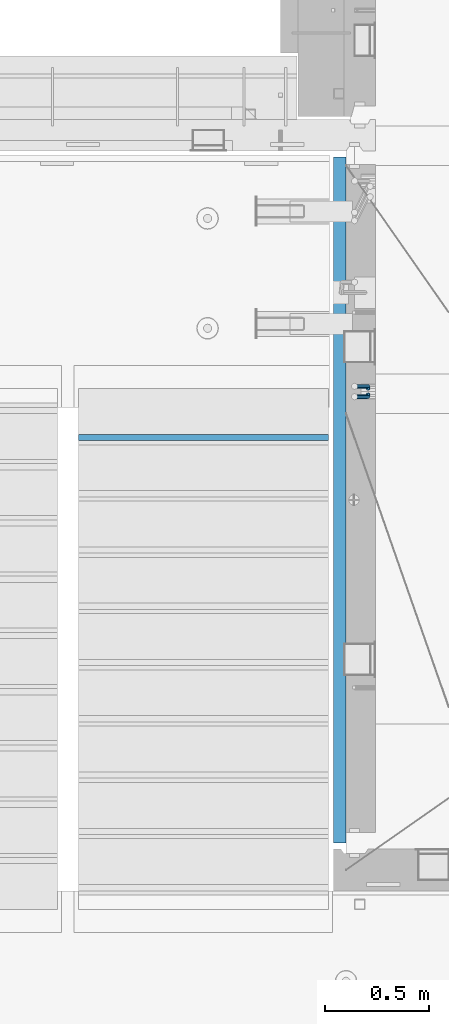
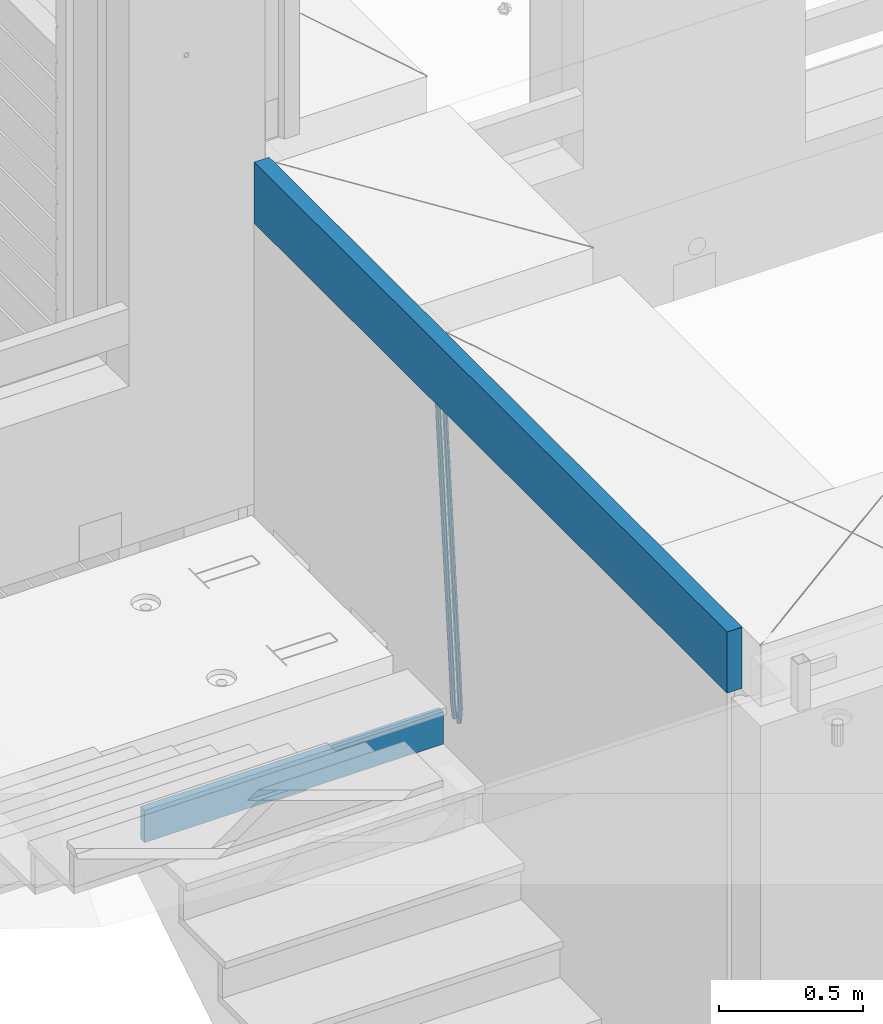
# One storey, part 120 of 349: 4 beams, 2 elements without a shape of their own.
"""IFC2X3 building model written with IfcOpenShell, lengths in millimetres."""

from ifc_helpers import new_model, si_unit, frame, origin_with_axes, place, context, subcontext, project, spatial, faceted_brep, material, type_object, element, aggregate, save


model = new_model("IFC2X3")

# Units and contexts
model_context = context("Model", 3, precision=1e-05, world=origin_with_axes())
body_context = subcontext(model_context, "Body", "Model", "MODEL_VIEW")
ifc_project = project(units=[si_unit("LENGTHUNIT", "METRE", prefix="MILLI"), si_unit("AREAUNIT", "SQUARE_METRE"), si_unit("VOLUMEUNIT", "CUBIC_METRE"), si_unit("MASSUNIT", "GRAM", prefix="KILO"), si_unit("TIMEUNIT", "SECOND"), si_unit("PLANEANGLEUNIT", "RADIAN"), si_unit("SOLIDANGLEUNIT", "STERADIAN"), si_unit("THERMODYNAMICTEMPERATUREUNIT", "DEGREE_CELSIUS"), si_unit("LUMINOUSINTENSITYUNIT", "LUMEN")], contexts=[model_context])

# Site, building, storey
site_placement = place(None, origin_with_axes())
site = spatial("IfcSite", under=ifc_project, at=site_placement, CompositionType="ELEMENT")
building_placement = place(site_placement, origin_with_axes())
building = spatial("IfcBuilding", under=site, at=building_placement, CompositionType="ELEMENT")
storey_placement = place(building_placement, origin_with_axes())
storey = spatial("IfcBuildingStorey", under=building, at=storey_placement, Name="4", CompositionType="ELEMENT", Elevation=0.0)

# Assembly, beams
assembly_1_placement = place(storey_placement, origin_with_axes())
assembly_1 = element("IfcElementAssembly", 1, at=assembly_1_placement, inside=storey, AssemblyPlace="NOTDEFINED", PredefinedType="REINFORCEMENT_UNIT")
ifc_material_1 = material()
beam_type_1 = type_object("IfcBeamType", Name="D20", PredefinedType="NOTDEFINED")
beam_1_placement = place(assembly_1_placement, frame((22375.0000022791, 19290.4700000039, 91985.0), z_axis=(-0.15890508605452, 0.973589036334047, -0.163931577056242), x_axis=(-0.0263727870048703, 0.161796289029781, 0.986471711181718)))
beam_1 = element("IfcBeam", 2, at=beam_1_placement, type_object=beam_type_1, material=ifc_material_1, Name="JM20", ObjectType="D20", context=body_context, shape_type="Brep", body=[
    faceted_brep([(0.0, -10.0, 0.0), (-4.19531716033816e-08, -7.07106781186667, -7.07106781187031), (60.5120847452927, -7.07106784077769, -7.0710678127632), (60.5120847456128, -10.000000028911, -8.96534402272664e-10), (0.0, 0.0, -10.0), (60.5120847479557, -2.89146555587649e-08, -10.0000000008984), (4.196772351861e-08, 7.07106781186303, -7.07106781186667), (60.5120847520593, 7.07106778294838, -7.0710678127632), (0.0, 10.0, 0.0), (60.5120847551734, 9.99999997108898, -8.94715412869118e-10), (4.196772351861e-08, 7.07106781185939, 7.07106781185939), (60.512084755479, 7.07106778295201, 7.07106781097195), (0.0, 0.0, 10.0), (60.512084752816, -2.89110175799578e-08, 9.9999999991071), (-4.19531716033816e-08, -7.07106781187031, 7.07106781185939), (60.5120847487415, -7.07106784077769, 7.07106781096832), (61.1107048256381, -7.07106784106145, -7.07106781277048), (61.616696962592, -10.0000000294385, -9.12905306904577e-10), (61.0120847479702, -2.91511241812259e-08, -10.0000000009038), (61.3786070335627, 7.07106778254092, -7.0710678127723), (61.9955678984406, 9.99999997037958, -9.2018126451876e-10), (62.5015600354091, 7.07106778200614, 7.07106781093921), (62.6001801130624, -2.9907823773101e-08, 9.99999999907436), (62.2336578274699, -7.07106784159623, 7.07106781094103), (61.7013993430301, -7.09359767751084, -7.16550506250837), (62.7066844218498, -10.0415735305724, -0.174261679103211), (61.505464887392, -0.0188181720659486, -10.0788791204338), (62.2336568017054, 7.03845510227256, -7.207768842012), (63.4594101385883, 9.94416717476997, -0.234031689273024), (64.464695217408, 6.99619132171574, 6.75721169413032), (64.6606296730461, -0.0785881837327906, 9.67058575205397), (63.9324377587182, -7.1358614580713, 6.79947547363395), (179.287252569251, -11.5784709304826, -25.9645361348155), (180.292537648071, -14.5264467835441, -18.973292751414), (179.091318113613, -4.50369142503769, -28.877910192741), (179.819510027926, 2.55358184929719, -26.0067999143191), (181.045263364809, 5.45929392180187, -19.033062761582), (182.050548443614, 2.511318068744, -12.0418193781786), (182.246482899252, -4.56346143670453, -9.12844532025679), (181.518290984939, -11.6207347110394, -11.9995555986786), (179.796944029818, -11.5979112078276, -26.0460230258138), (180.785917787493, -14.5452649264626, -19.0521718709458), (179.631039013402, -4.52427706319941, -28.9641980384947), (180.385387646791, 2.53199856077117, -26.0972695639282), (181.618102731314, 5.43744510340548, -19.1246454201662), (182.607076488988, 2.49009138477413, -12.1307942652963), (182.772981505375, -4.58354275985403, -9.21261925261729), (182.018632872001, -11.6398183838246, -12.0795477271802), (180.306575384253, -11.6215474691344, -26.1267734773298), (181.279244090445, -14.5681079330752, -19.1303214631914), (180.170689328603, -4.54931932109321, -29.0497458967745), (180.951186131948, 2.5057611781267, -26.1870011206463), (182.190861352254, 5.41092355571527, -19.2154962132006), (183.16353005846, 2.46436309177807, -12.2190441990567), (183.299416114096, -4.60786505625947, -9.29607177961748), (182.518919310765, -11.662945555483, -12.1588165557403), (300.637581828458, -17.193417372393, -45.2021641841727), (301.610250534635, -20.1399778363302, -38.2057121700307), (300.501695772793, -10.1211892243555, -48.125136603612), (301.282192576138, -3.06610872513556, -45.2623918274874), (302.521867796473, -0.160946347543359, -38.2908869200398), (303.494536502651, -3.10750681148056, -31.2944349058978), (303.630422558286, -10.1797349595217, -28.3714624864531), (302.849925754956, -17.2348154587417, -31.2342072625831), (301.135146648914, -17.2164568742628, -45.2810403078945), (302.103568397841, -20.1628206848691, -38.2839150477537), (301.007079483054, -10.1445907761881, -48.2052522115043), (301.794386909154, -3.08982563961035, -45.3435870847131), (303.035874914756, -0.184747202180006, -38.3723695478091), (304.004296663683, -3.13111101278264, -31.3752442876664), (304.132363829543, -10.2029771108573, -28.4510323840584), (303.345056403443, -17.2577422474315, -31.3126975108532), (301.632689949649, -17.2405558216851, -45.3597353949606), (302.596865217929, -20.1867113775443, -38.3619373656909), (301.512440876206, -10.1690694440185, -48.2851865283189), (302.306558273951, -3.11463305844518, -45.424601167904), (303.549858941391, -0.209639824737678, -38.4536714215171), (304.514034209686, -3.15579538060047, -31.4558733922438), (304.634283283129, -10.2272817582634, -28.5304222588836), (303.840165885384, -17.2817181438368, -31.3910076193022), (1282.62444446853, -64.7506719518351, -200.525713980774), (1283.58861973681, -67.6968275076943, -193.527915951503), (1282.50419539507, -57.6791855741649, -203.451165114133), (1283.29831279283, -50.6247491885915, -200.590579753716), (1284.54161346027, -47.7197559548877, -193.619650007329), (1285.50578872855, -50.6659115107432, -186.621851978058), (1285.62603780199, -57.7373978884098, -183.696400844703), (1284.83192040426, -64.7918342739831, -186.556986205121), (1283.16036625447, -64.7766270183929, -200.610482102403), (1284.18303170854, -67.7256152948248, -193.621935615638), (1282.99823367732, -57.703112193376, -203.529308414698), (1283.79160904189, -50.6486398706256, -200.668605684988), (1285.07574381966, -47.7456242614098, -193.704134774427), (1286.09840927372, -50.6946125378345, -186.715588287659), (1286.26054185088, -57.7681273628514, -183.796761975365), (1285.4671664863, -64.8225996856127, -186.657464705073), (1283.69517474226, -64.7992414390355, -200.702893843656), (1284.77620887742, -67.7506978399178, -193.72443311951), (1283.49124566819, -57.7239592457336, -203.61449796867), (1284.28388054106, -50.6694556112197, -200.753667286384), (1285.60876460234, -47.7681630887928, -193.796237610821), (1286.68979873748, -50.7196194896715, -186.817776886675), (1286.89372781155, -57.7949016829771, -183.906172761662), (1286.10109293868, -64.8494053174909, -186.767003443949), (1305.19726392522, -65.7084590385093, -204.418327587487), (1306.27829806038, -68.6599154393916, -197.43986686334), (1304.99333485115, -58.6331768452073, -207.3299317125), (1305.78596972401, -51.5786732107008, -204.469101030216), (1307.11085378527, -48.6773806882629, -197.511671354648), (1308.19188792045, -51.6288370891452, -190.533210630503), (1308.39581699451, -58.7041192824508, -187.62160650549), (1307.60318212165, -65.758622916961, -190.482437187782), (1305.83218118416, -65.7353065667266, -204.528037531872), (1306.8626665273, -68.6846255078017, -197.540842275655), (1305.64065308902, -58.6605487498273, -207.441784472648), (1306.40027680244, -51.6046492357418, -204.575249657393), (1307.66607505539, -48.7008582650778, -197.607610303868), (1308.69656039854, -51.6501772061529, -190.620415047653), (1308.88808849367, -58.7249350230522, -187.706668106881), (1308.12846478027, -65.7808345371377, -190.573202922138), (1306.46882402551, -65.7602792894941, -204.627733284394), (1307.44862319478, -68.7076100329687, -197.632600773693), (1306.28973061276, -58.6860092309689, -207.543427447275), (1307.01625344875, -51.6288113137889, -204.671709165457), (1308.2228053096, -48.7226963654903, -197.694792061111), (1309.20260447887, -51.6700271089649, -190.699659550409), (1309.38169789161, -58.74429716749, -187.783965387529), (1308.65517505561, -65.80149508467, -190.655683669345), (1405.22131312029, -69.6339088545756, -220.091982741469), (1406.20111228956, -72.5812395980538, -213.096850230768), (1405.04221970754, -62.5596387960541, -223.007676904353), (1405.76874254357, -55.5024408788704, -220.135958622533), (1406.97529440439, -52.5963259305718, -213.159041518189), (1407.95509357366, -55.54365667405, -206.163909007488), (1408.13418698641, -62.6179267325751, -203.248214844601), (1407.40766415041, -69.6751246497552, -206.119933126425)], [[[0, 1, 2, 3]], [[1, 4, 5, 2]], [[4, 6, 7, 5]], [[6, 8, 9, 7]], [[8, 10, 11, 9]], [[10, 12, 13, 11]], [[12, 14, 15, 13]], [[14, 0, 3, 15]], [[14, 12, 10, 8, 6, 4, 1, 0]], [[3, 2, 16, 17]], [[2, 5, 18, 16]], [[5, 7, 19, 18]], [[7, 9, 20, 19]], [[9, 11, 21, 20]], [[11, 13, 22, 21]], [[13, 15, 23, 22]], [[15, 3, 17, 23]], [[17, 16, 24, 25]], [[16, 18, 26, 24]], [[18, 19, 27, 26]], [[19, 20, 28, 27]], [[20, 21, 29, 28]], [[21, 22, 30, 29]], [[22, 23, 31, 30]], [[23, 17, 25, 31]], [[25, 24, 32, 33]], [[24, 26, 34, 32]], [[26, 27, 35, 34]], [[27, 28, 36, 35]], [[28, 29, 37, 36]], [[29, 30, 38, 37]], [[30, 31, 39, 38]], [[31, 25, 33, 39]], [[33, 32, 40, 41]], [[32, 34, 42, 40]], [[34, 35, 43, 42]], [[35, 36, 44, 43]], [[36, 37, 45, 44]], [[37, 38, 46, 45]], [[38, 39, 47, 46]], [[39, 33, 41, 47]], [[41, 40, 48, 49]], [[40, 42, 50, 48]], [[42, 43, 51, 50]], [[43, 44, 52, 51]], [[44, 45, 53, 52]], [[45, 46, 54, 53]], [[46, 47, 55, 54]], [[47, 41, 49, 55]], [[49, 48, 56, 57]], [[48, 50, 58, 56]], [[50, 51, 59, 58]], [[51, 52, 60, 59]], [[52, 53, 61, 60]], [[53, 54, 62, 61]], [[54, 55, 63, 62]], [[55, 49, 57, 63]], [[57, 56, 64, 65]], [[56, 58, 66, 64]], [[58, 59, 67, 66]], [[59, 60, 68, 67]], [[60, 61, 69, 68]], [[61, 62, 70, 69]], [[62, 63, 71, 70]], [[63, 57, 65, 71]], [[65, 64, 72, 73]], [[64, 66, 74, 72]], [[66, 67, 75, 74]], [[67, 68, 76, 75]], [[68, 69, 77, 76]], [[69, 70, 78, 77]], [[70, 71, 79, 78]], [[71, 65, 73, 79]], [[73, 72, 80, 81]], [[72, 74, 82, 80]], [[74, 75, 83, 82]], [[75, 76, 84, 83]], [[76, 77, 85, 84]], [[77, 78, 86, 85]], [[78, 79, 87, 86]], [[79, 73, 81, 87]], [[81, 80, 88, 89]], [[80, 82, 90, 88]], [[82, 83, 91, 90]], [[83, 84, 92, 91]], [[84, 85, 93, 92]], [[85, 86, 94, 93]], [[86, 87, 95, 94]], [[87, 81, 89, 95]], [[89, 88, 96, 97]], [[88, 90, 98, 96]], [[90, 91, 99, 98]], [[91, 92, 100, 99]], [[92, 93, 101, 100]], [[93, 94, 102, 101]], [[94, 95, 103, 102]], [[95, 89, 97, 103]], [[97, 96, 104, 105]], [[96, 98, 106, 104]], [[98, 99, 107, 106]], [[99, 100, 108, 107]], [[100, 101, 109, 108]], [[101, 102, 110, 109]], [[102, 103, 111, 110]], [[103, 97, 105, 111]], [[105, 104, 112, 113]], [[104, 106, 114, 112]], [[106, 107, 115, 114]], [[107, 108, 116, 115]], [[108, 109, 117, 116]], [[109, 110, 118, 117]], [[110, 111, 119, 118]], [[111, 105, 113, 119]], [[113, 112, 120, 121]], [[112, 114, 122, 120]], [[114, 115, 123, 122]], [[115, 116, 124, 123]], [[116, 117, 125, 124]], [[117, 118, 126, 125]], [[118, 119, 127, 126]], [[119, 113, 121, 127]], [[121, 120, 128, 129]], [[120, 122, 130, 128]], [[122, 123, 131, 130]], [[123, 124, 132, 131]], [[124, 125, 133, 132]], [[125, 126, 134, 133]], [[126, 127, 135, 134]], [[127, 121, 129, 135]], [[130, 131, 132, 133, 134, 135, 129, 128]]]),
])
beam_2_placement = place(assembly_1_placement, frame((22375.0000022791, 19260.4700000039, 91985.0), z_axis=(-0.158495816053634, -0.973655762329485, -0.163931488055477), x_axis=(-0.0263727879979646, -0.161796198987477, 0.986471725923465)))
beam_2 = element("IfcBeam", 3, at=beam_2_placement, type_object=beam_type_1, material=ifc_material_1, Name="JM20", ObjectType="D20", context=body_context, shape_type="Brep", body=[
    faceted_brep([(0.0, -10.0, 0.0), (-4.19531716033816e-08, -7.07106781186667, -7.07106781187031), (60.5120052037528, -7.07106781749098, -7.07106782543269), (60.5120052045822, -10.0000000056316, -1.35623849928379e-08), (0.0, 0.0, -10.0), (60.512005203942, -5.62431523576379e-09, -10.0000000135624), (4.196772351861e-08, 7.07106781186303, -7.07106781186667), (60.5120052050625, 7.07106780623872, -7.07106782543269), (0.0, 10.0, 0.0), (60.5120052064449, 9.99999999437205, -1.35623849928379e-08), (4.196772351861e-08, 7.07106781185939, 7.07106781185939), (60.5120052072889, 7.07106780623872, 7.07106779830065), (0.0, 0.0, 10.0), (60.5120052070852, -5.62795321457088e-09, 9.99999998643762), (-4.19531716033816e-08, -7.07106781187031, 7.07106781185939), (60.5120052059501, -7.07106781749098, 7.07106779830065), (61.3783176868601, -7.07106781757102, -7.07106782562914), (61.9952377020818, -10.0000000057662, -1.38970790430903e-08), (61.0120052039565, -5.67160896025598e-09, -10.0000000136788), (61.1108811377926, 7.07106780618051, -7.07106782556366), (61.6170253073215, 9.99999999427382, -1.38097675517201e-08), (62.2339453225432, 7.07106780607864, 7.07106779791502), (62.6002578054613, -5.81712811253965e-09, 9.99999998597195), (62.5013818716106, -7.07106781767652, 7.07106779785681), (62.2331604305218, -7.03851970548931, -7.2077492888784), (63.4588326085068, -9.94427367315438, -0.23401532828575), (61.5053853412101, 0.0187854284049536, -10.0788869429962), (61.7018281175842, 7.09356809489327, -7.16555479231465), (62.7074152454443, 10.041516558791, -0.174343299004249), (63.9330874234438, 7.13576259111869, 6.79939066157385), (64.6608625127556, 0.078457457228069, 9.6705283156989), (64.4644197363668, -6.99632520926025, 6.75719616502465), (179.818932802998, -2.5614449136192, -26.0086288006423), (181.044604980983, -5.46719888128791, -19.034894840057), (179.091157713687, 4.49586022027506, -28.8797664547601), (179.287600490061, 11.5706428867597, -25.9664343040859), (180.293187617921, 14.5185913506575, -18.9752228107754), (181.51885979592, 11.6128373829924, -12.0014888501901), (182.246634885232, 4.55553224909454, -9.13035119606502), (182.050192108843, -2.51925041739014, -12.0436833467465), (180.384803383684, -2.53989940806059, -26.0991062826724), (181.617449868121, -5.44538782921518, -19.126487449299), (179.630864755702, 4.51640954987306, -28.9660606284815), (179.797281007268, 11.5900489573214, -26.0479275136822), (180.786567755189, 14.5373767847341, -19.0541097400928), (182.019214239626, 11.6318883635759, -12.0814909067267), (182.773152867594, 4.5755794056422, -9.21453656090307), (182.606736616028, -2.49806000179888, -12.1326696757169), (180.950594849404, -2.51369963445904, -26.1888475202795), (182.190214025846, -5.41890367426822, -19.2173500092686), (180.170501221772, 4.54141556354443, -29.051616675737), (180.306901410135, 11.613651120846, -26.1286861303379), (181.279894034014, 14.5601873642845, -19.132268955691), (182.519513210456, 11.6549833244717, -12.16077144468), (183.299606838089, 4.59986812646821, -9.29800228921522), (183.163206649726, -2.4723674308334, -12.2209328346216), (301.281596738394, 3.05026059481679, -45.2665532172323), (302.521215914836, 0.145056555003976, -38.2950557062213), (300.501503110776, 10.1053757928166, -48.1293223726971), (300.637903299124, 17.1776113501182, -45.2063918272906), (301.610895923019, 20.1241475935603, -38.2099746526364), (302.850515099461, 17.2189435537439, -31.2384771416328), (303.630608727079, 10.163828355744, -28.375707986168), (303.494208538745, 3.09159279844243, -31.2986385315744), (301.793789297284, 3.07394376027514, -45.3477580501058), (303.035224417355, 0.168823687501572, -38.3765484452742), (301.006883331909, 10.128743964, -48.2094471532764), (301.135465363477, 17.2006180191747, -45.285277089446), (302.104213781728, 20.14695801567, -38.2881870233177), (303.345648901799, 17.2418379429, -31.3169774184789), (304.132554867159, 10.1870377391679, -28.455288315301), (304.003972835591, 3.11516368399316, -31.3794583791459), (302.305958891287, 3.09871749445665, -45.4287821432372), (303.549209831341, 0.193682665365486, -38.4578608624288), (301.512241238641, 10.1531893083702, -48.2893910778876), (301.633005909636, 17.2246841938904, -45.3639817491057), (302.597510597858, 20.1708163533331, -38.3662192661868), (303.840761537926, 17.2657815242455, -31.3952979853784), (304.634479190572, 10.211309710332, -28.5346890507208), (304.513714519577, 3.13981482481177, -31.4600983795099), (1283.29235311947, 50.544232039254, -200.613633821762), (1284.53560405952, 47.6391972101628, -193.642712540946), (1282.49863546679, 57.5987038531639, -203.474242756405), (1282.6194001378, 64.6701987386878, -200.548833427623), (1283.58390482602, 67.6163308981268, -193.551070944704), (1284.82715576609, 64.7112960690356, -186.580149663889), (1285.62087341874, 57.6568242551293, -183.719540729246), (1285.50010874774, 50.5853293696091, -186.644950058035), (1283.86584870378, 50.5719692160856, -200.704356616399), (1285.05399320807, 47.6642691581874, -193.72471790167), (1283.12497041782, 57.628996611762, -203.573324351266), (1283.26535480202, 64.701440406865, -200.651018717188), (1284.20476658808, 67.6463589453451, -193.649286721222), (1285.39291109238, 64.7386588874433, -186.6696480065), (1286.13378937833, 57.6816314917669, -183.800680271634), (1285.99340499415, 50.6091876966675, -186.722985905704), (1284.44060590031, 50.5936921758439, -200.788496023008), (1285.57352274218, 47.68390478734, -193.800772463459), (1283.75268322045, 57.6527210297136, -203.665215993606), (1283.91273047855, 64.7259079835276, -200.745788831606), (1284.82699416149, 67.6698760489453, -193.740375374167), (1285.95991100336, 64.7600886604341, -186.752651814619), (1286.64783368325, 57.7010598065717, -183.875931844028), (1286.48778642512, 50.6278728527504, -186.795359006021), (1306.02894027183, 51.4096237058839, -203.948838607132), (1307.16185711371, 48.4998363173727, -196.961115047583), (1305.34101759194, 58.4686525597535, -206.825558577722), (1305.50106485008, 65.5418395135639, -203.90613141573), (1306.415328533, 68.4858075789816, -196.900717958291), (1307.54824537487, 65.5760201904777, -189.912994398743), (1308.23616805475, 58.5169913366044, -187.036274428152), (1308.07612079663, 51.4438043827904, -189.955701590145), (1306.55429855913, 51.4294796328759, -204.025746447209), (1307.74597489809, 48.5219130607366, -197.046624762064), (1305.83539902292, 58.4873377158401, -206.897931678046), (1306.0103978878, 65.5610897659317, -203.980693299985), (1306.97678319212, 68.507027769072, -196.982909990227), (1308.16845953107, 65.5994611969327, -190.00378830509), (1308.88735906727, 58.5416031139684, -187.131603074253), (1308.71236020241, 51.4678510638769, -190.048841452306), (1307.07832423707, 51.4505295560484, -204.110977857723), (1308.32861102538, 48.5453173445967, -197.141389009383), (1306.32852641959, 58.507146466156, -206.978137563652), (1306.51843896537, 65.5814975934481, -204.063324856921), (1307.5368136808, 68.5295239925508, -197.073997489359), (1308.78710046913, 65.6243117811064, -190.104408641026), (1309.53689828661, 58.5676948709952, -187.237248935096), (1309.34698574082, 51.4933437436994, -190.152061641827), (1405.73383542724, 55.413485988287, -220.157039583137), (1406.98412221558, 52.5082737768425, -213.187450734797), (1404.98403760976, 62.4701028983982, -223.024199289066), (1405.17395015556, 69.544454025694, -220.109386582335), (1406.19232487098, 72.492480424793, -213.12005921478), (1407.44261165931, 69.5872682133449, -206.15047036644), (1408.1924094768, 62.5306513032374, -203.28331066051), (1408.00249693099, 55.4563001759452, -206.198123367241)], [[[0, 1, 2, 3]], [[1, 4, 5, 2]], [[4, 6, 7, 5]], [[6, 8, 9, 7]], [[8, 10, 11, 9]], [[10, 12, 13, 11]], [[12, 14, 15, 13]], [[14, 0, 3, 15]], [[14, 12, 10, 8, 6, 4, 1, 0]], [[3, 2, 16, 17]], [[2, 5, 18, 16]], [[5, 7, 19, 18]], [[7, 9, 20, 19]], [[9, 11, 21, 20]], [[11, 13, 22, 21]], [[13, 15, 23, 22]], [[15, 3, 17, 23]], [[17, 16, 24, 25]], [[16, 18, 26, 24]], [[18, 19, 27, 26]], [[19, 20, 28, 27]], [[20, 21, 29, 28]], [[21, 22, 30, 29]], [[22, 23, 31, 30]], [[23, 17, 25, 31]], [[25, 24, 32, 33]], [[24, 26, 34, 32]], [[26, 27, 35, 34]], [[27, 28, 36, 35]], [[28, 29, 37, 36]], [[29, 30, 38, 37]], [[30, 31, 39, 38]], [[31, 25, 33, 39]], [[33, 32, 40, 41]], [[32, 34, 42, 40]], [[34, 35, 43, 42]], [[35, 36, 44, 43]], [[36, 37, 45, 44]], [[37, 38, 46, 45]], [[38, 39, 47, 46]], [[39, 33, 41, 47]], [[41, 40, 48, 49]], [[40, 42, 50, 48]], [[42, 43, 51, 50]], [[43, 44, 52, 51]], [[44, 45, 53, 52]], [[45, 46, 54, 53]], [[46, 47, 55, 54]], [[47, 41, 49, 55]], [[49, 48, 56, 57]], [[48, 50, 58, 56]], [[50, 51, 59, 58]], [[51, 52, 60, 59]], [[52, 53, 61, 60]], [[53, 54, 62, 61]], [[54, 55, 63, 62]], [[55, 49, 57, 63]], [[57, 56, 64, 65]], [[56, 58, 66, 64]], [[58, 59, 67, 66]], [[59, 60, 68, 67]], [[60, 61, 69, 68]], [[61, 62, 70, 69]], [[62, 63, 71, 70]], [[63, 57, 65, 71]], [[65, 64, 72, 73]], [[64, 66, 74, 72]], [[66, 67, 75, 74]], [[67, 68, 76, 75]], [[68, 69, 77, 76]], [[69, 70, 78, 77]], [[70, 71, 79, 78]], [[71, 65, 73, 79]], [[73, 72, 80, 81]], [[72, 74, 82, 80]], [[74, 75, 83, 82]], [[75, 76, 84, 83]], [[76, 77, 85, 84]], [[77, 78, 86, 85]], [[78, 79, 87, 86]], [[79, 73, 81, 87]], [[81, 80, 88, 89]], [[80, 82, 90, 88]], [[82, 83, 91, 90]], [[83, 84, 92, 91]], [[84, 85, 93, 92]], [[85, 86, 94, 93]], [[86, 87, 95, 94]], [[87, 81, 89, 95]], [[89, 88, 96, 97]], [[88, 90, 98, 96]], [[90, 91, 99, 98]], [[91, 92, 100, 99]], [[92, 93, 101, 100]], [[93, 94, 102, 101]], [[94, 95, 103, 102]], [[95, 89, 97, 103]], [[97, 96, 104, 105]], [[96, 98, 106, 104]], [[98, 99, 107, 106]], [[99, 100, 108, 107]], [[100, 101, 109, 108]], [[101, 102, 110, 109]], [[102, 103, 111, 110]], [[103, 97, 105, 111]], [[105, 104, 112, 113]], [[104, 106, 114, 112]], [[106, 107, 115, 114]], [[107, 108, 116, 115]], [[108, 109, 117, 116]], [[109, 110, 118, 117]], [[110, 111, 119, 118]], [[111, 105, 113, 119]], [[113, 112, 120, 121]], [[112, 114, 122, 120]], [[114, 115, 123, 122]], [[115, 116, 124, 123]], [[116, 117, 125, 124]], [[117, 118, 126, 125]], [[118, 119, 127, 126]], [[119, 113, 121, 127]], [[121, 120, 128, 129]], [[120, 122, 130, 128]], [[122, 123, 131, 130]], [[123, 124, 132, 131]], [[124, 125, 133, 132]], [[125, 126, 134, 133]], [[126, 127, 135, 134]], [[127, 121, 129, 135]], [[130, 131, 132, 133, 134, 135, 129, 128]]]),
])
ifc_material_2 = material(Name="CONCRETE/C25/30")
beam_type_2 = type_object("IfcBeamType", Name="260X60", PredefinedType="NOTDEFINED")
beam_3_placement = place(assembly_1_placement, frame((22240.0000000001, 20400.0, 93600.0), z_axis=(0.0, 0.0, 1.0), x_axis=(0.0, -1.0, 0.0)))
beam_3 = element("IfcBeam", 4, at=beam_3_placement, type_object=beam_type_2, material=ifc_material_2, ObjectType="260X60", context=body_context, shape_type="Brep", body=[
    faceted_brep([(0.0, 30.0, -130.0), (0.0, 30.0, 130.0), (3290.0, 30.0, 130.0), (3290.0, 30.0, -130.0), (0.0, -30.0, 130.0), (3290.0, -30.0, 130.0), (0.0, -30.0, -130.0), (3290.0, -30.0, -130.0)], [[[0, 1, 2, 3]], [[1, 4, 5, 2]], [[4, 6, 7, 5]], [[6, 0, 3, 7]], [[5, 7, 3, 2]], [[6, 4, 1, 0]]]),
])
aggregate(assembly_1, [beam_1, beam_2, beam_3])

# Assembly, beam
assembly_2_placement = place(storey_placement, origin_with_axes())
assembly_2 = element("IfcElementAssembly", 5, at=assembly_2_placement, inside=storey, Name="E9", AssemblyPlace="NOTDEFINED", PredefinedType="NOTDEFINED")
ifc_material_3 = material(Name="Undefined/C32/40")
beam_type_3 = type_object("IfcBeamType", PredefinedType="NOTDEFINED")
beam_4_placement = place(assembly_2_placement, frame((20985.002175553, 19055.001025346, 92161.803607297), z_axis=(0.0, -1.0, 0.0), x_axis=(1.0, 0.0, 0.0)))
beam_4 = element("IfcBeam", 6, at=beam_4_placement, type_object=beam_type_3, material=ifc_material_3, Name="E9", context=body_context, shape_type="Brep", body=[
    faceted_brep([(0.0, 68.5, -15.0), (0.0, 68.5, 15.0), (1200.0, 68.5, 15.0), (1200.0, 68.5, -15.0), (0.0, -68.5, 15.0), (1200.0, -68.5, 15.0), (0.0, -68.5, -15.0), (1200.0, -68.5, -15.0)], [[[0, 1, 2, 3]], [[1, 4, 5, 2]], [[4, 6, 7, 5]], [[6, 0, 3, 7]], [[5, 7, 3, 2]], [[6, 4, 1, 0]]]),
])
aggregate(assembly_2, [beam_4])

save(model, "model.ifc")
